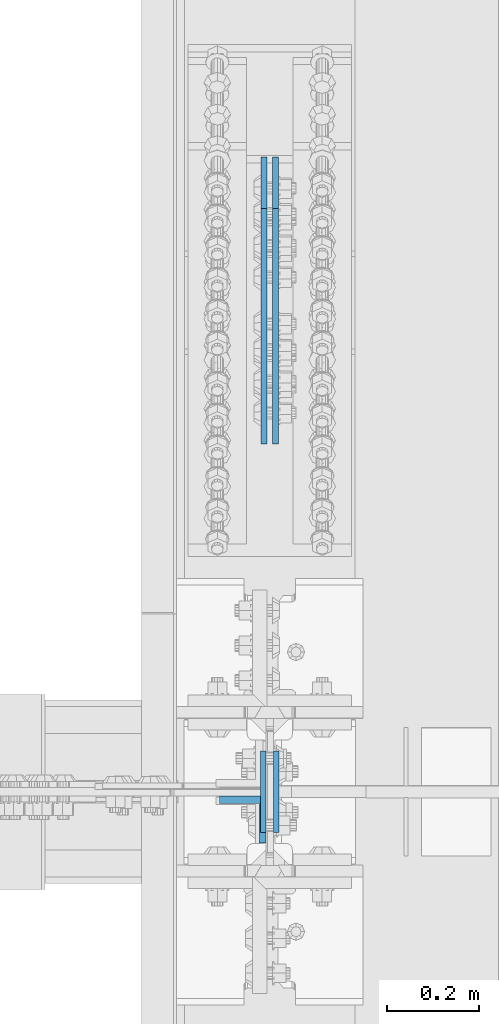
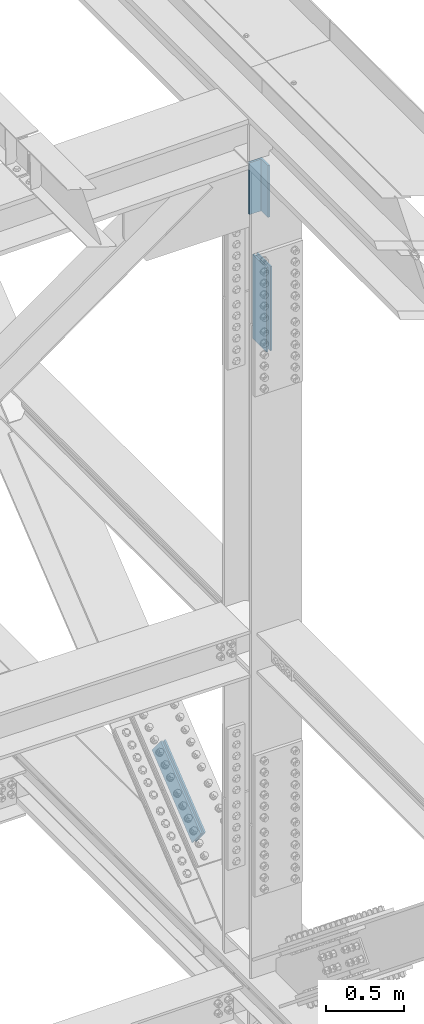
# One storey, part 2710 of 3843: 3 beams, 2 members, 3 elements without a shape of their own.
"""IFC2X3 building model written with IfcOpenShell, lengths in millimetres."""

from ifc_helpers import new_model, si_unit, frame, origin_with_axes, place, context, subcontext, project, spatial, faceted_brep, material, type_object, element, aggregate, save


model = new_model("IFC2X3")

# Units and contexts
model_context = context("Model", 3, precision=1e-05, world=origin_with_axes())
body_context = subcontext(model_context, "Body", "Model", "MODEL_VIEW")
ifc_project = project(units=[si_unit("LENGTHUNIT", "METRE", prefix="MILLI"), si_unit("AREAUNIT", "SQUARE_METRE"), si_unit("VOLUMEUNIT", "CUBIC_METRE"), si_unit("MASSUNIT", "GRAM", prefix="KILO"), si_unit("TIMEUNIT", "SECOND"), si_unit("PLANEANGLEUNIT", "RADIAN"), si_unit("SOLIDANGLEUNIT", "STERADIAN"), si_unit("THERMODYNAMICTEMPERATUREUNIT", "DEGREE_CELSIUS"), si_unit("LUMINOUSINTENSITYUNIT", "LUMEN")], contexts=[model_context])

# Site, building, storey
site_placement = place(None, origin_with_axes())
site = spatial("IfcSite", under=ifc_project, at=site_placement, CompositionType="ELEMENT")
building_placement = place(site_placement, origin_with_axes())
building = spatial("IfcBuilding", under=site, at=building_placement, Name="Undefined", CompositionType="ELEMENT")
storey_placement = place(building_placement, origin_with_axes())
storey = spatial("IfcBuildingStorey", under=building, at=storey_placement, Name="Undefined", CompositionType="ELEMENT", Elevation=0.0)

# Assembly, beams
assembly_1_placement = place(storey_placement, origin_with_axes())
assembly_1 = element("IfcElementAssembly", 1, at=assembly_1_placement, inside=storey, Name="BEAM", AssemblyPlace="NOTDEFINED", PredefinedType="RIGID_FRAME")
ifc_material = material(Name="STEEL/A572-50")
beam_type_1 = type_object("IfcBeamType", PredefinedType="NOTDEFINED")
beam_1_placement = place(assembly_1_placement, frame((85634.5125, 58915.3000157179, 45227.8798102186), z_axis=(0.0, 1.0, 0.0), x_axis=(0.0, 0.0, -1.0)))
beam_1 = element("IfcBeam", 2, at=beam_1_placement, type_object=beam_type_1, material=ifc_material, Name="PLATE", context=body_context, shape_type="Brep", body=[
    faceted_brep([(1.45519152283669e-11, 6.35000000000582, -88.8999999998996), (0.0, 6.34999999999854, 88.9000015258789), (660.399999982677, 6.35000000000582, 88.8999999999651), (660.399999982707, 6.35000000000582, -88.8999999998268), (0.0, -6.34999999999854, 88.9000015258789), (660.399999982677, -6.35000000000582, 88.8999999999651), (1.45519152283669e-11, -6.35000000000582, -88.8999999998996), (660.399999982707, -6.35000000000582, -88.8999999998268)], [[[0, 1, 2, 3]], [[1, 4, 5, 2]], [[4, 6, 7, 5]], [[6, 0, 3, 7]], [[5, 7, 3, 2]], [[6, 4, 1, 0]]]),
])
beam_2_placement = place(assembly_1_placement, frame((85663.0875, 58915.3000157179, 45227.8798102186), z_axis=(0.0, 1.0, 0.0), x_axis=(0.0, 0.0, -1.0)))
beam_2 = element("IfcBeam", 3, at=beam_2_placement, type_object=beam_type_1, material=ifc_material, Name="PLATE", context=body_context, shape_type="Brep", body=[
    faceted_brep([(1.45519152283669e-11, 6.35000000000582, -88.8999999998996), (0.0, 6.34999999999854, 88.9000015258789), (660.399999982677, 6.35000000000582, 88.8999999999651), (660.399999982707, 6.35000000000582, -88.8999999998268), (0.0, -6.34999999999854, 88.9000015258789), (660.399999982677, -6.35000000000582, 88.8999999999651), (1.45519152283669e-11, -6.35000000000582, -88.8999999998996), (660.399999982707, -6.35000000000582, -88.8999999998268)], [[[0, 1, 2, 3]], [[1, 4, 5, 2]], [[4, 6, 7, 5]], [[6, 0, 3, 7]], [[5, 7, 3, 2]], [[6, 4, 1, 0]]]),
])
aggregate(assembly_1, [beam_1, beam_2])

# Assembly, beam
assembly_2_placement = place(storey_placement, origin_with_axes())
assembly_2 = element("IfcElementAssembly", 4, at=assembly_2_placement, inside=storey, Name="BEAM", AssemblyPlace="NOTDEFINED", PredefinedType="RIGID_FRAME")
beam_type_2 = type_object("IfcBeamType", Name="L4X4X5/8", PredefinedType="NOTDEFINED")
beam_3_placement = place(assembly_2_placement, frame((85590.0625000214, 58854.9750003815, 46043.0518102257), z_axis=(0.0, -1.0, 0.0), x_axis=(0.0, 0.0, -1.0)))
beam_3 = element("IfcBeam", 5, at=beam_3_placement, type_object=beam_type_2, material=ifc_material, Name="ANGLE", ObjectType="L4X4X5/8", context=body_context, shape_type="Brep", body=[
    faceted_brep([(0.0, 50.8000000000029, -50.8000000000029), (0.0, 50.8000000000029, 50.8000000000029), (406.399999999841, 50.799999998344, 50.8000000000029), (406.399999999841, 50.799999998344, -50.8000000000029), (0.0, 34.9250000000029, 50.8000000000029), (406.399999999892, 34.924999998344, 50.8000000000029), (0.0, 34.9250000000029, -34.9250000000029), (406.399999999892, 34.924999998344, -34.9250000000029), (0.0, -50.8000000000029, -34.9250000000029), (406.400000000162, -50.8000000016473, -34.9250000000029), (0.0, -50.8000000000029, -50.8000000000029), (406.400000000162, -50.8000000016473, -50.8000000000029)], [[[0, 1, 2, 3]], [[1, 4, 5, 2]], [[4, 6, 7, 5]], [[6, 8, 9, 7]], [[8, 10, 11, 9]], [[10, 0, 3, 11]], [[5, 7, 9, 11, 3, 2]], [[10, 8, 6, 4, 1, 0]]]),
])
aggregate(assembly_2, [beam_3])

# Assembly, members
assembly_3_placement = place(storey_placement, origin_with_axes())
assembly_3 = element("IfcElementAssembly", 6, at=assembly_3_placement, inside=storey, Name="BEAM", AssemblyPlace="NOTDEFINED", PredefinedType="RIGID_FRAME")
member_type = type_object("IfcMemberType", PredefinedType="NOTDEFINED")
member_1_placement = place(assembly_3_placement, frame((85661.5, 60242.9468263965, 40627.4848306806), z_axis=(0.0, -0.62928248312701, 0.777176657156856), x_axis=(0.0, -0.77717665715686, -0.629282483127005)))
member_1 = element("IfcMember", 7, at=member_1_placement, type_object=member_type, material=ifc_material, Name="PLATE", context=body_context, shape_type="Brep", body=[
    faceted_brep([(1.45519152283669e-11, 6.35000000000582, -88.8999999998996), (0.0, 6.34999999999854, 88.9000015258789), (660.399999982677, 6.35000000000582, 88.8999999999651), (660.399999982707, 6.35000000000582, -88.8999999998268), (0.0, -6.34999999999854, 88.9000015258789), (660.399999982677, -6.35000000000582, 88.8999999999651), (1.45519152283669e-11, -6.35000000000582, -88.8999999998996), (660.399999982707, -6.35000000000582, -88.8999999998268)], [[[0, 1, 2, 3]], [[1, 4, 5, 2]], [[4, 6, 7, 5]], [[6, 0, 3, 7]], [[5, 7, 3, 2]], [[6, 4, 1, 0]]]),
])
member_2_placement = place(assembly_3_placement, frame((85636.1, 60242.9468263965, 40627.4848306806), z_axis=(0.0, -0.62928248312701, 0.777176657156856), x_axis=(0.0, -0.77717665715686, -0.629282483127005)))
member_2 = element("IfcMember", 8, at=member_2_placement, type_object=member_type, material=ifc_material, Name="PLATE", context=body_context, shape_type="Brep", body=[
    faceted_brep([(1.45519152283669e-11, 6.35000000000582, -88.8999999998996), (0.0, 6.34999999999854, 88.9000015258789), (660.399999982677, 6.35000000000582, 88.8999999999651), (660.399999982707, 6.35000000000582, -88.8999999998268), (0.0, -6.34999999999854, 88.9000015258789), (660.399999982677, -6.35000000000582, 88.8999999999651), (1.45519152283669e-11, -6.35000000000582, -88.8999999998996), (660.399999982707, -6.35000000000582, -88.8999999998268)], [[[0, 1, 2, 3]], [[1, 4, 5, 2]], [[4, 6, 7, 5]], [[6, 0, 3, 7]], [[5, 7, 3, 2]], [[6, 4, 1, 0]]]),
])
aggregate(assembly_3, [member_1, member_2])

save(model, "model.ifc")
